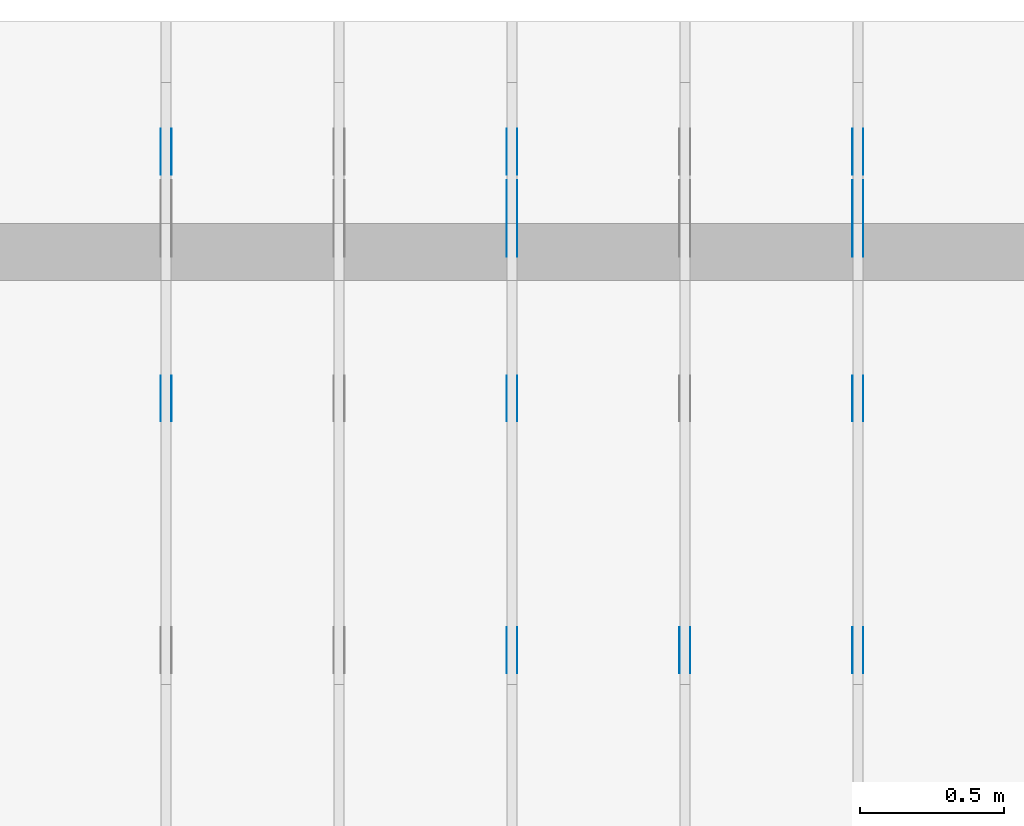
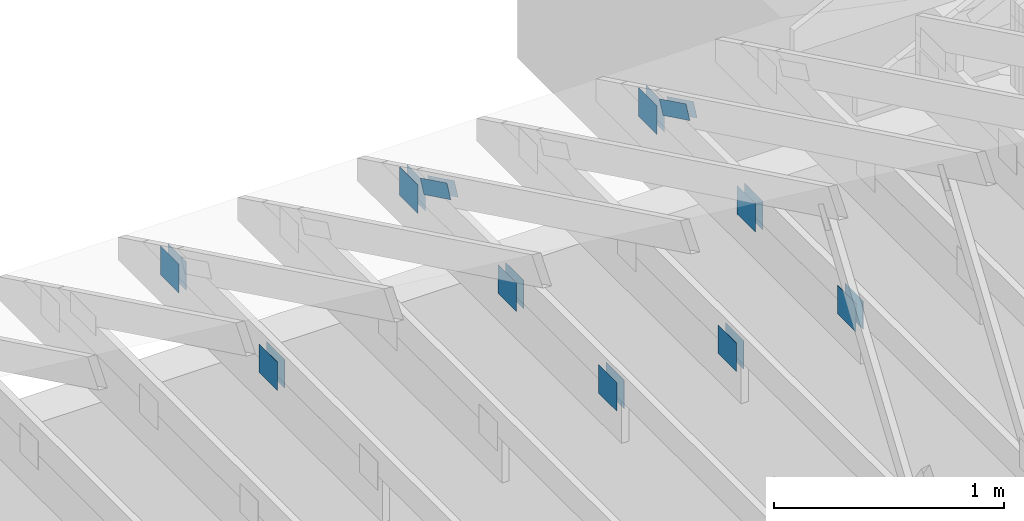
# One storey, part 95 of 159: 22 plates, 4 elements without a shape of their own.
"""IFC2X3 building model written with IfcOpenShell, lengths in millimetres."""

from ifc_helpers import new_model, si_unit, frame, origin, origin_with_axes, origin_2d, place, context, project, spatial, faceted_brep, element, aggregate, save


model = new_model("IFC2X3")

# Units and contexts
model_context = context("Model", 3, precision=1e-05, world=origin())
plan_context = context("Plan", 2, precision=1e-05, world=origin_2d())
ifc_project = project(units=[si_unit("LENGTHUNIT", "METRE", prefix="MILLI"), si_unit("AREAUNIT", "SQUARE_METRE"), si_unit("VOLUMEUNIT", "CUBIC_METRE"), si_unit("SOLIDANGLEUNIT", "STERADIAN"), si_unit("PLANEANGLEUNIT", "RADIAN"), si_unit("MASSUNIT", "GRAM"), si_unit("TIMEUNIT", "SECOND"), si_unit("THERMODYNAMICTEMPERATUREUNIT", "DEGREE_CELSIUS"), si_unit("LUMINOUSINTENSITYUNIT", "LUMEN")], contexts=[model_context, plan_context])

# Site, building, storey
site_placement = place(None, origin_with_axes())
site = spatial("IfcSite", under=ifc_project, at=site_placement, CompositionType="ELEMENT")
building_placement = place(site_placement, origin_with_axes())
building = spatial("IfcBuilding", under=site, at=building_placement, Name="Plan 1", CompositionType="ELEMENT")
storey_placement = place(building_placement, origin_with_axes())
storey = spatial("IfcBuildingStorey", under=building, at=storey_placement, Name="Etasje 1", CompositionType="ELEMENT", Elevation=0.0)

# Assembly, plates
assembly_1_placement = place(storey_placement, frame((9075.022261404752, 9699.99999999999, 1.1021457184401395e-15), z_axis=(-1.0, 1.836909530733566e-16, 6.123031769111886e-17), x_axis=(-1.836909530733566e-16, -1.0, 0.0)))
assembly_1 = element("IfcElementAssembly", 1, at=assembly_1_placement, inside=storey, Name="T2 (93)", AssemblyPlace="FACTORY", PredefinedType="TRUSS")
plate_1_placement = place(assembly_1_placement, frame((584.1466632894789, 280.2959373746887, 0.0), z_axis=(0.0, 0.0, 1.0), x_axis=(0.8987940462991671, 0.43837114678907757, 0.0)))
plate_1 = element("IfcPlate", 2, at=plate_1_placement, Name="GNT100S 76x258", context=model_context, shape_type="Brep", body=[
    faceted_brep([(257.99998123479463, 76.00002691228985, 1.0), (0.0, 76.00002691228985, 1.0), (1.3453948213282274e-05, 1.802431262376558e-05, 1.0), (257.99999468874273, 1.802431262376558e-05, 1.0), (0.0, 76.00002691228985, 0.0), (257.99998123479463, 76.00002691228985, 3.159484163061836e-14), (257.99999468874273, 0.0, 3.1594843278197396e-14), (1.3453948213282274e-05, 0.0, 1.6475790465982693e-21), (258.00000746284013, 8.521039129974861e-06, 1.1615733003639174e-30), (258.00000746284013, 8.521039130036092e-06, 1.0), (7.462840130756376e-06, 8.521039177428358e-06, 1.0), (7.462840130756376e-06, 8.521039177367127e-06, 9.4039548065783e-38), (258.00000746284013, 76.00000852103915, 0.0), (258.00000746284013, 76.00000852103915, 1.0), (258.00000746284013, 8.52103914894542e-06, 1.0), (258.00000746284013, 8.52103914894542e-06, 0.0), (7.462840130756376e-06, 76.0000085210392, 0.0), (7.462840130756376e-06, 76.0000085210392, 1.0), (258.00000746284013, 76.00000852103913, 1.0), (258.00000746284013, 76.00000852103913, -1.5777218104420236e-30), (7.462840130756377e-06, 8.521039177367129e-06, -9.4039548065783e-38), (7.4628401308176075e-06, 8.521039177367129e-06, 1.0), (7.462840140124616e-06, 76.0000085210392, 1.0), (7.4628401400633854e-06, 76.0000085210392, -5.69871103679771e-31)], [[[0, 1, 2, 3]], [[4, 5, 6, 7]], [[8, 9, 10, 11]], [[12, 13, 14, 15]], [[16, 17, 18, 19]], [[20, 21, 22, 23]]]),
])
plate_2_placement = place(assembly_1_placement, frame((584.1466632894789, 280.2959373746887, -37.0), z_axis=(0.0, 0.0, 1.0), x_axis=(0.8987940462991671, 0.43837114678907757, 0.0)))
plate_2 = element("IfcPlate", 3, at=plate_2_placement, Name="GNT100S 76x258", context=model_context, shape_type="Brep", body=[
    faceted_brep([(257.99998123479463, 76.00002691228985, 1.0), (0.0, 76.00002691228985, 1.0), (1.3453948213282274e-05, 1.802431262376558e-05, 1.0), (257.99999468874273, 1.802431262376558e-05, 1.0), (0.0, 76.00002691228985, 0.0), (257.99998123479463, 76.00002691228985, 3.159484163061836e-14), (257.99999468874273, 0.0, 3.1594843278197396e-14), (1.3453948213282274e-05, 0.0, 1.6475790465982693e-21), (258.00000746284013, 8.521039129974861e-06, 1.1615733003639174e-30), (258.00000746284013, 8.521039130036092e-06, 1.0), (7.462840130756376e-06, 8.521039177428358e-06, 1.0), (7.462840130756376e-06, 8.521039177367127e-06, 9.4039548065783e-38), (258.00000746284013, 76.00000852103915, 0.0), (258.00000746284013, 76.00000852103915, 1.0), (258.00000746284013, 8.52103914894542e-06, 1.0), (258.00000746284013, 8.52103914894542e-06, 0.0), (7.462840130756376e-06, 76.0000085210392, 0.0), (7.462840130756376e-06, 76.0000085210392, 1.0), (258.00000746284013, 76.00000852103913, 1.0), (258.00000746284013, 76.00000852103913, -1.5777218104420236e-30), (7.462840130756377e-06, 8.521039177367129e-06, -9.4039548065783e-38), (7.4628401308176075e-06, 8.521039177367129e-06, 1.0), (7.462840140124616e-06, 76.0000085210392, 1.0), (7.4628401400633854e-06, 76.0000085210392, -5.69871103679771e-31)], [[[0, 1, 2, 3]], [[4, 5, 6, 7]], [[8, 9, 10, 11]], [[12, 13, 14, 15]], [[16, 17, 18, 19]], [[20, 21, 22, 23]]]),
])
plate_3_placement = place(assembly_1_placement, frame((2260.0, 299.0, 0.0), z_axis=(0.0, 0.0, 1.0), x_axis=(-1.0, 1.2246063538223773e-16, 0.0)))
plate_3 = element("IfcPlate", 4, at=plate_3_placement, Name="GNT100S 152x159", context=model_context, shape_type="Brep", body=[
    faceted_brep([(159.0, 152.0, 1.0), (0.0, 152.0, 1.0), (0.0, 0.0, 1.0), (159.0, 0.0, 1.0), (0.0, 152.0, 0.0), (159.0, 152.0, 1.9471241025775798e-14), (159.0, 0.0, 1.9471241025775798e-14), (0.0, 0.0, 0.0), (159.0, -2.92068615386637e-14, 1.788345410772899e-30), (159.0, -2.914563122097258e-14, 1.0), (1.1247455413666031e-32, 6.123031769111886e-17, 1.0), (0.0, 0.0, 0.0), (159.0, 152.00000000000003, 0.0), (159.0, 152.00000000000003, 1.0), (159.0, 0.0, 1.0), (159.0, 0.0, 0.0), (0.0, 152.0, 0.0), (0.0, 152.0, 1.0), (159.0, 152.00000000000003, 1.0), (159.0, 152.00000000000003, 0.0), (0.0, 0.0, 0.0), (6.123031769111886e-17, -7.498303609110687e-33, 1.0), (1.8675246895791253e-14, 152.0, 1.0), (1.8614016578100134e-14, 152.0, -1.1397421485848245e-30)], [[[0, 1, 2, 3]], [[4, 5, 6, 7]], [[8, 9, 10, 11]], [[12, 13, 14, 15]], [[16, 17, 18, 19]], [[20, 21, 22, 23]]]),
])
plate_4_placement = place(assembly_1_placement, frame((2260.0, 299.0, -37.0), z_axis=(0.0, 0.0, 1.0), x_axis=(-1.0, 1.2246063538223773e-16, 0.0)))
plate_4 = element("IfcPlate", 5, at=plate_4_placement, Name="GNT100S 152x159", context=model_context, shape_type="Brep", body=[
    faceted_brep([(159.0, 152.0, 1.0), (0.0, 152.0, 1.0), (0.0, 0.0, 1.0), (159.0, 0.0, 1.0), (0.0, 152.0, 0.0), (159.0, 152.0, 1.9471241025775798e-14), (159.0, 0.0, 1.9471241025775798e-14), (0.0, 0.0, 0.0), (159.0, -2.92068615386637e-14, 1.788345410772899e-30), (159.0, -2.914563122097258e-14, 1.0), (1.1247455413666031e-32, 6.123031769111886e-17, 1.0), (0.0, 0.0, 0.0), (159.0, 152.00000000000003, 0.0), (159.0, 152.00000000000003, 1.0), (159.0, 0.0, 1.0), (159.0, 0.0, 0.0), (0.0, 152.0, 0.0), (0.0, 152.0, 1.0), (159.0, 152.00000000000003, 1.0), (159.0, 152.00000000000003, 0.0), (0.0, 0.0, 0.0), (6.123031769111886e-17, -7.498303609110687e-33, 1.0), (1.8675246895791253e-14, 152.0, 1.0), (1.8614016578100134e-14, 152.0, -1.1397421485848245e-30)], [[[0, 1, 2, 3]], [[4, 5, 6, 7]], [[8, 9, 10, 11]], [[12, 13, 14, 15]], [[16, 17, 18, 19]], [[20, 21, 22, 23]]]),
])
plate_5_placement = place(assembly_1_placement, frame((1227.851282296476, 147.0, 0.0), z_axis=(0.0, 0.0, 1.0), x_axis=(1.0, 0.0, 0.0)))
plate_5 = element("IfcPlate", 6, at=plate_5_placement, Name="GNT100S 152x159", context=model_context, shape_type="Brep", body=[
    faceted_brep([(159.00003606289897, 152.0, 1.0), (3.6062898971067625e-05, 152.0, 1.0), (3.6062898971067625e-05, 0.0, 1.0), (159.00003606289897, 0.0, 1.0), (3.6062898971067625e-05, 152.0, 4.4162855217223885e-21), (159.00003606289897, 152.0, 1.947124544206132e-14), (159.00003606289897, 0.0, 1.947124544206132e-14), (3.6062898971067625e-05, 0.0, 4.4162855217223885e-21), (159.0, 8.447997618295233e-14, 1.788345410772899e-30), (159.0, 8.454120650064345e-14, 1.0), (1.1247455413666031e-32, 1.1374806803930715e-13, 1.0), (0.0, 1.1368683772161603e-13, 0.0), (159.0, 152.0000000000001, 0.0), (159.0, 152.0000000000001, 1.0), (159.0, 1.1368683772161603e-13, 1.0), (159.0, 1.1368683772161603e-13, 0.0), (4.861730685829017e-63, 152.0000000000001, 0.0), (-3.7491518045553436e-33, 152.0000000000001, 1.0), (159.0, 152.0000000000001, 1.0), (159.0, 152.0000000000001, 0.0), (1.392216238198645e-29, 1.1368683772161603e-13, -8.524584255963745e-46), (6.123031769113279e-17, 1.1368683772161603e-13, 1.0), (1.8675246895791266e-14, 152.0000000000001, 1.0), (1.8614016578100147e-14, 152.0000000000001, -1.1397421485848253e-30)], [[[0, 1, 2, 3]], [[4, 5, 6, 7]], [[8, 9, 10, 11]], [[12, 13, 14, 15]], [[16, 17, 18, 19]], [[20, 21, 22, 23]]]),
])
plate_6_placement = place(assembly_1_placement, frame((1227.851282296476, 147.0, -37.0), z_axis=(0.0, 0.0, 1.0), x_axis=(1.0, 0.0, 0.0)))
plate_6 = element("IfcPlate", 7, at=plate_6_placement, Name="GNT100S 152x159", context=model_context, shape_type="Brep", body=[
    faceted_brep([(159.00003606289897, 152.0, 1.0), (3.6062898971067625e-05, 152.0, 1.0), (3.6062898971067625e-05, 0.0, 1.0), (159.00003606289897, 0.0, 1.0), (3.6062898971067625e-05, 152.0, 4.4162855217223885e-21), (159.00003606289897, 152.0, 1.947124544206132e-14), (159.00003606289897, 0.0, 1.947124544206132e-14), (3.6062898971067625e-05, 0.0, 4.4162855217223885e-21), (159.0, 8.447997618295233e-14, 1.788345410772899e-30), (159.0, 8.454120650064345e-14, 1.0), (1.1247455413666031e-32, 1.1374806803930715e-13, 1.0), (0.0, 1.1368683772161603e-13, 0.0), (159.0, 152.0000000000001, 0.0), (159.0, 152.0000000000001, 1.0), (159.0, 1.1368683772161603e-13, 1.0), (159.0, 1.1368683772161603e-13, 0.0), (4.861730685829017e-63, 152.0000000000001, 0.0), (-3.7491518045553436e-33, 152.0000000000001, 1.0), (159.0, 152.0000000000001, 1.0), (159.0, 152.0000000000001, 0.0), (1.392216238198645e-29, 1.1368683772161603e-13, -8.524584255963745e-46), (6.123031769113279e-17, 1.1368683772161603e-13, 1.0), (1.8675246895791266e-14, 152.0000000000001, 1.0), (1.8614016578100147e-14, 152.0000000000001, -1.1397421485848253e-30)], [[[0, 1, 2, 3]], [[4, 5, 6, 7]], [[8, 9, 10, 11]], [[12, 13, 14, 15]], [[16, 17, 18, 19]], [[20, 21, 22, 23]]]),
])
plate_7_placement = place(assembly_1_placement, frame((372.12651478826456, 147.0, 0.0), z_axis=(0.0, 0.0, 1.0), x_axis=(1.0, 0.0, 0.0)))
plate_7 = element("IfcPlate", 8, at=plate_7_placement, Name="GNT100S 152x159", context=model_context, shape_type="Brep", body=[
    faceted_brep([(159.0000110906417, 152.0, 1.0), (1.109064169213525e-05, 152.0, 1.0), (1.109064169213525e-05, 0.0, 1.0), (159.0000110906417, 0.0, 1.0), (1.109064169213525e-05, 152.0, 1.3581670284156189e-21), (159.0000110906417, 152.0, 1.9471242383942826e-14), (159.0000110906417, 0.0, 1.9471242383942826e-14), (1.109064169213525e-05, 0.0, 1.3581670284156189e-21), (159.0, 1.9816681390456836e-13, 1.788345410772899e-30), (159.0, 1.9822804422225948e-13, 1.0), (1.1247455413666031e-32, 2.274349057609232e-13, 1.0), (0.0, 2.2737367544323206e-13, 0.0), (159.0, 152.00000000000023, 0.0), (159.0, 152.00000000000023, 1.0), (159.0, 2.2737367544323206e-13, 1.0), (159.0, 2.2737367544323206e-13, 0.0), (0.0, 152.00000000000023, 0.0), (-3.7491518045553436e-33, 152.00000000000023, 1.0), (159.0, 152.00000000000023, 1.0), (159.0, 152.00000000000023, 0.0), (2.78443247639729e-29, 2.2737367544323206e-13, -1.704916851192749e-45), (6.123031769114671e-17, 2.2737367544323206e-13, 1.0), (1.8675246895791282e-14, 152.00000000000023, 1.0), (1.8614016578100163e-14, 152.00000000000023, -1.1397421485848262e-30)], [[[0, 1, 2, 3]], [[4, 5, 6, 7]], [[8, 9, 10, 11]], [[12, 13, 14, 15]], [[16, 17, 18, 19]], [[20, 21, 22, 23]]]),
])
plate_8_placement = place(assembly_1_placement, frame((372.12651478826456, 147.0, -37.0), z_axis=(0.0, 0.0, 1.0), x_axis=(1.0, 0.0, 0.0)))
plate_8 = element("IfcPlate", 9, at=plate_8_placement, Name="GNT100S 152x159", context=model_context, shape_type="Brep", body=[
    faceted_brep([(159.0000110906417, 152.0, 1.0), (1.109064169213525e-05, 152.0, 1.0), (1.109064169213525e-05, 0.0, 1.0), (159.0000110906417, 0.0, 1.0), (1.109064169213525e-05, 152.0, 1.3581670284156189e-21), (159.0000110906417, 152.0, 1.9471242383942826e-14), (159.0000110906417, 0.0, 1.9471242383942826e-14), (1.109064169213525e-05, 0.0, 1.3581670284156189e-21), (159.0, 1.9816681390456836e-13, 1.788345410772899e-30), (159.0, 1.9822804422225948e-13, 1.0), (1.1247455413666031e-32, 2.274349057609232e-13, 1.0), (0.0, 2.2737367544323206e-13, 0.0), (159.0, 152.00000000000023, 0.0), (159.0, 152.00000000000023, 1.0), (159.0, 2.2737367544323206e-13, 1.0), (159.0, 2.2737367544323206e-13, 0.0), (0.0, 152.00000000000023, 0.0), (-3.7491518045553436e-33, 152.00000000000023, 1.0), (159.0, 152.00000000000023, 1.0), (159.0, 152.00000000000023, 0.0), (2.78443247639729e-29, 2.2737367544323206e-13, -1.704916851192749e-45), (6.123031769114671e-17, 2.2737367544323206e-13, 1.0), (1.8675246895791282e-14, 152.00000000000023, 1.0), (1.8614016578100163e-14, 152.00000000000023, -1.1397421485848262e-30)], [[[0, 1, 2, 3]], [[4, 5, 6, 7]], [[8, 9, 10, 11]], [[12, 13, 14, 15]], [[16, 17, 18, 19]], [[20, 21, 22, 23]]]),
])
aggregate(assembly_1, [plate_1, plate_2, plate_3, plate_4, plate_5, plate_6, plate_7, plate_8])

assembly_2_placement = place(storey_placement, frame((8475.022261404752, 9699.99999999999, 1.1021457184401395e-15), z_axis=(-1.0, 1.836909530733566e-16, 6.123031769111886e-17), x_axis=(-1.836909530733566e-16, -1.0, 0.0)))
assembly_2 = element("IfcElementAssembly", 10, at=assembly_2_placement, inside=storey, Name="T2 (92)", AssemblyPlace="FACTORY", PredefinedType="TRUSS")
plate_9_placement = place(assembly_2_placement, frame((2260.0, 299.0, 0.0), z_axis=(0.0, 0.0, 1.0), x_axis=(-1.0, 1.2246063538223773e-16, 0.0)))
plate_9 = element("IfcPlate", 11, at=plate_9_placement, Name="GNT100S 152x159", context=model_context, shape_type="Brep", body=[
    faceted_brep([(159.0, 152.0, 1.0), (0.0, 152.0, 1.0), (0.0, 0.0, 1.0), (159.0, 0.0, 1.0), (0.0, 152.0, 0.0), (159.0, 152.0, 1.9471241025775798e-14), (159.0, 0.0, 1.9471241025775798e-14), (0.0, 0.0, 0.0), (159.0, -2.92068615386637e-14, 1.788345410772899e-30), (159.0, -2.914563122097258e-14, 1.0), (1.1247455413666031e-32, 6.123031769111886e-17, 1.0), (0.0, 0.0, 0.0), (159.0, 152.00000000000003, 0.0), (159.0, 152.00000000000003, 1.0), (159.0, 0.0, 1.0), (159.0, 0.0, 0.0), (0.0, 152.0, 0.0), (0.0, 152.0, 1.0), (159.0, 152.00000000000003, 1.0), (159.0, 152.00000000000003, 0.0), (0.0, 0.0, 0.0), (6.123031769111886e-17, -7.498303609110687e-33, 1.0), (1.8675246895791253e-14, 152.0, 1.0), (1.8614016578100134e-14, 152.0, -1.1397421485848245e-30)], [[[0, 1, 2, 3]], [[4, 5, 6, 7]], [[8, 9, 10, 11]], [[12, 13, 14, 15]], [[16, 17, 18, 19]], [[20, 21, 22, 23]]]),
])
plate_10_placement = place(assembly_2_placement, frame((2260.0, 299.0, -37.0), z_axis=(0.0, 0.0, 1.0), x_axis=(-1.0, 1.2246063538223773e-16, 0.0)))
plate_10 = element("IfcPlate", 12, at=plate_10_placement, Name="GNT100S 152x159", context=model_context, shape_type="Brep", body=[
    faceted_brep([(159.0, 152.0, 1.0), (0.0, 152.0, 1.0), (0.0, 0.0, 1.0), (159.0, 0.0, 1.0), (0.0, 152.0, 0.0), (159.0, 152.0, 1.9471241025775798e-14), (159.0, 0.0, 1.9471241025775798e-14), (0.0, 0.0, 0.0), (159.0, -2.92068615386637e-14, 1.788345410772899e-30), (159.0, -2.914563122097258e-14, 1.0), (1.1247455413666031e-32, 6.123031769111886e-17, 1.0), (0.0, 0.0, 0.0), (159.0, 152.00000000000003, 0.0), (159.0, 152.00000000000003, 1.0), (159.0, 0.0, 1.0), (159.0, 0.0, 0.0), (0.0, 152.0, 0.0), (0.0, 152.0, 1.0), (159.0, 152.00000000000003, 1.0), (159.0, 152.00000000000003, 0.0), (0.0, 0.0, 0.0), (6.123031769111886e-17, -7.498303609110687e-33, 1.0), (1.8675246895791253e-14, 152.0, 1.0), (1.8614016578100134e-14, 152.0, -1.1397421485848245e-30)], [[[0, 1, 2, 3]], [[4, 5, 6, 7]], [[8, 9, 10, 11]], [[12, 13, 14, 15]], [[16, 17, 18, 19]], [[20, 21, 22, 23]]]),
])
aggregate(assembly_2, [plate_9, plate_10])

assembly_3_placement = place(storey_placement, frame((7875.0222614047525, 9699.99999999999, 1.1021457184401395e-15), z_axis=(-1.0, 1.836909530733566e-16, 6.123031769111886e-17), x_axis=(-1.836909530733566e-16, -1.0, 0.0)))
assembly_3 = element("IfcElementAssembly", 13, at=assembly_3_placement, inside=storey, Name="T2 (91)", AssemblyPlace="FACTORY", PredefinedType="TRUSS")
plate_11_placement = place(assembly_3_placement, frame((584.1466632894789, 280.2959373746887, 0.0), z_axis=(0.0, 0.0, 1.0), x_axis=(0.8987940462991671, 0.43837114678907757, 0.0)))
plate_11 = element("IfcPlate", 14, at=plate_11_placement, Name="GNT100S 76x258", context=model_context, shape_type="Brep", body=[
    faceted_brep([(257.99998123479463, 76.00002691228985, 1.0), (0.0, 76.00002691228985, 1.0), (1.3453948213282274e-05, 1.802431262376558e-05, 1.0), (257.99999468874273, 1.802431262376558e-05, 1.0), (0.0, 76.00002691228985, 0.0), (257.99998123479463, 76.00002691228985, 3.159484163061836e-14), (257.99999468874273, 0.0, 3.1594843278197396e-14), (1.3453948213282274e-05, 0.0, 1.6475790465982693e-21), (258.00000746284013, 8.521039129974861e-06, 1.1615733003639174e-30), (258.00000746284013, 8.521039130036092e-06, 1.0), (7.462840130756376e-06, 8.521039177428358e-06, 1.0), (7.462840130756376e-06, 8.521039177367127e-06, 9.4039548065783e-38), (258.00000746284013, 76.00000852103915, 0.0), (258.00000746284013, 76.00000852103915, 1.0), (258.00000746284013, 8.52103914894542e-06, 1.0), (258.00000746284013, 8.52103914894542e-06, 0.0), (7.462840130756376e-06, 76.0000085210392, 0.0), (7.462840130756376e-06, 76.0000085210392, 1.0), (258.00000746284013, 76.00000852103913, 1.0), (258.00000746284013, 76.00000852103913, -1.5777218104420236e-30), (7.462840130756377e-06, 8.521039177367129e-06, -9.4039548065783e-38), (7.4628401308176075e-06, 8.521039177367129e-06, 1.0), (7.462840140124616e-06, 76.0000085210392, 1.0), (7.4628401400633854e-06, 76.0000085210392, -5.69871103679771e-31)], [[[0, 1, 2, 3]], [[4, 5, 6, 7]], [[8, 9, 10, 11]], [[12, 13, 14, 15]], [[16, 17, 18, 19]], [[20, 21, 22, 23]]]),
])
plate_12_placement = place(assembly_3_placement, frame((584.1466632894789, 280.2959373746887, -37.0), z_axis=(0.0, 0.0, 1.0), x_axis=(0.8987940462991671, 0.43837114678907757, 0.0)))
plate_12 = element("IfcPlate", 15, at=plate_12_placement, Name="GNT100S 76x258", context=model_context, shape_type="Brep", body=[
    faceted_brep([(257.99998123479463, 76.00002691228985, 1.0), (0.0, 76.00002691228985, 1.0), (1.3453948213282274e-05, 1.802431262376558e-05, 1.0), (257.99999468874273, 1.802431262376558e-05, 1.0), (0.0, 76.00002691228985, 0.0), (257.99998123479463, 76.00002691228985, 3.159484163061836e-14), (257.99999468874273, 0.0, 3.1594843278197396e-14), (1.3453948213282274e-05, 0.0, 1.6475790465982693e-21), (258.00000746284013, 8.521039129974861e-06, 1.1615733003639174e-30), (258.00000746284013, 8.521039130036092e-06, 1.0), (7.462840130756376e-06, 8.521039177428358e-06, 1.0), (7.462840130756376e-06, 8.521039177367127e-06, 9.4039548065783e-38), (258.00000746284013, 76.00000852103915, 0.0), (258.00000746284013, 76.00000852103915, 1.0), (258.00000746284013, 8.52103914894542e-06, 1.0), (258.00000746284013, 8.52103914894542e-06, 0.0), (7.462840130756376e-06, 76.0000085210392, 0.0), (7.462840130756376e-06, 76.0000085210392, 1.0), (258.00000746284013, 76.00000852103913, 1.0), (258.00000746284013, 76.00000852103913, -1.5777218104420236e-30), (7.462840130756377e-06, 8.521039177367129e-06, -9.4039548065783e-38), (7.4628401308176075e-06, 8.521039177367129e-06, 1.0), (7.462840140124616e-06, 76.0000085210392, 1.0), (7.4628401400633854e-06, 76.0000085210392, -5.69871103679771e-31)], [[[0, 1, 2, 3]], [[4, 5, 6, 7]], [[8, 9, 10, 11]], [[12, 13, 14, 15]], [[16, 17, 18, 19]], [[20, 21, 22, 23]]]),
])
plate_13_placement = place(assembly_3_placement, frame((2260.0, 299.0, 0.0), z_axis=(0.0, 0.0, 1.0), x_axis=(-1.0, 1.2246063538223773e-16, 0.0)))
plate_13 = element("IfcPlate", 16, at=plate_13_placement, Name="GNT100S 152x159", context=model_context, shape_type="Brep", body=[
    faceted_brep([(159.0, 152.0, 1.0), (0.0, 152.0, 1.0), (0.0, 0.0, 1.0), (159.0, 0.0, 1.0), (0.0, 152.0, 0.0), (159.0, 152.0, 1.9471241025775798e-14), (159.0, 0.0, 1.9471241025775798e-14), (0.0, 0.0, 0.0), (159.0, -2.92068615386637e-14, 1.788345410772899e-30), (159.0, -2.914563122097258e-14, 1.0), (1.1247455413666031e-32, 6.123031769111886e-17, 1.0), (0.0, 0.0, 0.0), (159.0, 152.00000000000003, 0.0), (159.0, 152.00000000000003, 1.0), (159.0, 0.0, 1.0), (159.0, 0.0, 0.0), (0.0, 152.0, 0.0), (0.0, 152.0, 1.0), (159.0, 152.00000000000003, 1.0), (159.0, 152.00000000000003, 0.0), (0.0, 0.0, 0.0), (6.123031769111886e-17, -7.498303609110687e-33, 1.0), (1.8675246895791253e-14, 152.0, 1.0), (1.8614016578100134e-14, 152.0, -1.1397421485848245e-30)], [[[0, 1, 2, 3]], [[4, 5, 6, 7]], [[8, 9, 10, 11]], [[12, 13, 14, 15]], [[16, 17, 18, 19]], [[20, 21, 22, 23]]]),
])
plate_14_placement = place(assembly_3_placement, frame((2260.0, 299.0, -37.0), z_axis=(0.0, 0.0, 1.0), x_axis=(-1.0, 1.2246063538223773e-16, 0.0)))
plate_14 = element("IfcPlate", 17, at=plate_14_placement, Name="GNT100S 152x159", context=model_context, shape_type="Brep", body=[
    faceted_brep([(159.0, 152.0, 1.0), (0.0, 152.0, 1.0), (0.0, 0.0, 1.0), (159.0, 0.0, 1.0), (0.0, 152.0, 0.0), (159.0, 152.0, 1.9471241025775798e-14), (159.0, 0.0, 1.9471241025775798e-14), (0.0, 0.0, 0.0), (159.0, -2.92068615386637e-14, 1.788345410772899e-30), (159.0, -2.914563122097258e-14, 1.0), (1.1247455413666031e-32, 6.123031769111886e-17, 1.0), (0.0, 0.0, 0.0), (159.0, 152.00000000000003, 0.0), (159.0, 152.00000000000003, 1.0), (159.0, 0.0, 1.0), (159.0, 0.0, 0.0), (0.0, 152.0, 0.0), (0.0, 152.0, 1.0), (159.0, 152.00000000000003, 1.0), (159.0, 152.00000000000003, 0.0), (0.0, 0.0, 0.0), (6.123031769111886e-17, -7.498303609110687e-33, 1.0), (1.8675246895791253e-14, 152.0, 1.0), (1.8614016578100134e-14, 152.0, -1.1397421485848245e-30)], [[[0, 1, 2, 3]], [[4, 5, 6, 7]], [[8, 9, 10, 11]], [[12, 13, 14, 15]], [[16, 17, 18, 19]], [[20, 21, 22, 23]]]),
])
plate_15_placement = place(assembly_3_placement, frame((1227.851282296476, 147.0, 0.0), z_axis=(0.0, 0.0, 1.0), x_axis=(1.0, 0.0, 0.0)))
plate_15 = element("IfcPlate", 18, at=plate_15_placement, Name="GNT100S 152x159", context=model_context, shape_type="Brep", body=[
    faceted_brep([(159.00003606289897, 152.0, 1.0), (3.6062898971067625e-05, 152.0, 1.0), (3.6062898971067625e-05, 0.0, 1.0), (159.00003606289897, 0.0, 1.0), (3.6062898971067625e-05, 152.0, 4.4162855217223885e-21), (159.00003606289897, 152.0, 1.947124544206132e-14), (159.00003606289897, 0.0, 1.947124544206132e-14), (3.6062898971067625e-05, 0.0, 4.4162855217223885e-21), (159.0, 8.447997618295233e-14, 1.788345410772899e-30), (159.0, 8.454120650064345e-14, 1.0), (1.1247455413666031e-32, 1.1374806803930715e-13, 1.0), (0.0, 1.1368683772161603e-13, 0.0), (159.0, 152.0000000000001, 0.0), (159.0, 152.0000000000001, 1.0), (159.0, 1.1368683772161603e-13, 1.0), (159.0, 1.1368683772161603e-13, 0.0), (4.861730685829017e-63, 152.0000000000001, 0.0), (-3.7491518045553436e-33, 152.0000000000001, 1.0), (159.0, 152.0000000000001, 1.0), (159.0, 152.0000000000001, 0.0), (1.392216238198645e-29, 1.1368683772161603e-13, -8.524584255963745e-46), (6.123031769113279e-17, 1.1368683772161603e-13, 1.0), (1.8675246895791266e-14, 152.0000000000001, 1.0), (1.8614016578100147e-14, 152.0000000000001, -1.1397421485848253e-30)], [[[0, 1, 2, 3]], [[4, 5, 6, 7]], [[8, 9, 10, 11]], [[12, 13, 14, 15]], [[16, 17, 18, 19]], [[20, 21, 22, 23]]]),
])
plate_16_placement = place(assembly_3_placement, frame((1227.851282296476, 147.0, -37.0), z_axis=(0.0, 0.0, 1.0), x_axis=(1.0, 0.0, 0.0)))
plate_16 = element("IfcPlate", 19, at=plate_16_placement, Name="GNT100S 152x159", context=model_context, shape_type="Brep", body=[
    faceted_brep([(159.00003606289897, 152.0, 1.0), (3.6062898971067625e-05, 152.0, 1.0), (3.6062898971067625e-05, 0.0, 1.0), (159.00003606289897, 0.0, 1.0), (3.6062898971067625e-05, 152.0, 4.4162855217223885e-21), (159.00003606289897, 152.0, 1.947124544206132e-14), (159.00003606289897, 0.0, 1.947124544206132e-14), (3.6062898971067625e-05, 0.0, 4.4162855217223885e-21), (159.0, 8.447997618295233e-14, 1.788345410772899e-30), (159.0, 8.454120650064345e-14, 1.0), (1.1247455413666031e-32, 1.1374806803930715e-13, 1.0), (0.0, 1.1368683772161603e-13, 0.0), (159.0, 152.0000000000001, 0.0), (159.0, 152.0000000000001, 1.0), (159.0, 1.1368683772161603e-13, 1.0), (159.0, 1.1368683772161603e-13, 0.0), (4.861730685829017e-63, 152.0000000000001, 0.0), (-3.7491518045553436e-33, 152.0000000000001, 1.0), (159.0, 152.0000000000001, 1.0), (159.0, 152.0000000000001, 0.0), (1.392216238198645e-29, 1.1368683772161603e-13, -8.524584255963745e-46), (6.123031769113279e-17, 1.1368683772161603e-13, 1.0), (1.8675246895791266e-14, 152.0000000000001, 1.0), (1.8614016578100147e-14, 152.0000000000001, -1.1397421485848253e-30)], [[[0, 1, 2, 3]], [[4, 5, 6, 7]], [[8, 9, 10, 11]], [[12, 13, 14, 15]], [[16, 17, 18, 19]], [[20, 21, 22, 23]]]),
])
plate_17_placement = place(assembly_3_placement, frame((372.12651478826456, 147.0, 0.0), z_axis=(0.0, 0.0, 1.0), x_axis=(1.0, 0.0, 0.0)))
plate_17 = element("IfcPlate", 20, at=plate_17_placement, Name="GNT100S 152x159", context=model_context, shape_type="Brep", body=[
    faceted_brep([(159.0000110906417, 152.0, 1.0), (1.109064169213525e-05, 152.0, 1.0), (1.109064169213525e-05, 0.0, 1.0), (159.0000110906417, 0.0, 1.0), (1.109064169213525e-05, 152.0, 1.3581670284156189e-21), (159.0000110906417, 152.0, 1.9471242383942826e-14), (159.0000110906417, 0.0, 1.9471242383942826e-14), (1.109064169213525e-05, 0.0, 1.3581670284156189e-21), (159.0, 1.9816681390456836e-13, 1.788345410772899e-30), (159.0, 1.9822804422225948e-13, 1.0), (1.1247455413666031e-32, 2.274349057609232e-13, 1.0), (0.0, 2.2737367544323206e-13, 0.0), (159.0, 152.00000000000023, 0.0), (159.0, 152.00000000000023, 1.0), (159.0, 2.2737367544323206e-13, 1.0), (159.0, 2.2737367544323206e-13, 0.0), (0.0, 152.00000000000023, 0.0), (-3.7491518045553436e-33, 152.00000000000023, 1.0), (159.0, 152.00000000000023, 1.0), (159.0, 152.00000000000023, 0.0), (2.78443247639729e-29, 2.2737367544323206e-13, -1.704916851192749e-45), (6.123031769114671e-17, 2.2737367544323206e-13, 1.0), (1.8675246895791282e-14, 152.00000000000023, 1.0), (1.8614016578100163e-14, 152.00000000000023, -1.1397421485848262e-30)], [[[0, 1, 2, 3]], [[4, 5, 6, 7]], [[8, 9, 10, 11]], [[12, 13, 14, 15]], [[16, 17, 18, 19]], [[20, 21, 22, 23]]]),
])
plate_18_placement = place(assembly_3_placement, frame((372.12651478826456, 147.0, -37.0), z_axis=(0.0, 0.0, 1.0), x_axis=(1.0, 0.0, 0.0)))
plate_18 = element("IfcPlate", 21, at=plate_18_placement, Name="GNT100S 152x159", context=model_context, shape_type="Brep", body=[
    faceted_brep([(159.0000110906417, 152.0, 1.0), (1.109064169213525e-05, 152.0, 1.0), (1.109064169213525e-05, 0.0, 1.0), (159.0000110906417, 0.0, 1.0), (1.109064169213525e-05, 152.0, 1.3581670284156189e-21), (159.0000110906417, 152.0, 1.9471242383942826e-14), (159.0000110906417, 0.0, 1.9471242383942826e-14), (1.109064169213525e-05, 0.0, 1.3581670284156189e-21), (159.0, 1.9816681390456836e-13, 1.788345410772899e-30), (159.0, 1.9822804422225948e-13, 1.0), (1.1247455413666031e-32, 2.274349057609232e-13, 1.0), (0.0, 2.2737367544323206e-13, 0.0), (159.0, 152.00000000000023, 0.0), (159.0, 152.00000000000023, 1.0), (159.0, 2.2737367544323206e-13, 1.0), (159.0, 2.2737367544323206e-13, 0.0), (0.0, 152.00000000000023, 0.0), (-3.7491518045553436e-33, 152.00000000000023, 1.0), (159.0, 152.00000000000023, 1.0), (159.0, 152.00000000000023, 0.0), (2.78443247639729e-29, 2.2737367544323206e-13, -1.704916851192749e-45), (6.123031769114671e-17, 2.2737367544323206e-13, 1.0), (1.8675246895791282e-14, 152.00000000000023, 1.0), (1.8614016578100163e-14, 152.00000000000023, -1.1397421485848262e-30)], [[[0, 1, 2, 3]], [[4, 5, 6, 7]], [[8, 9, 10, 11]], [[12, 13, 14, 15]], [[16, 17, 18, 19]], [[20, 21, 22, 23]]]),
])
aggregate(assembly_3, [plate_11, plate_12, plate_13, plate_14, plate_15, plate_16, plate_17, plate_18])

assembly_4_placement = place(storey_placement, frame((6675.0222614047525, 9699.99999999999, 1.1021457184401395e-15), z_axis=(-1.0, 1.836909530733566e-16, 6.123031769111886e-17), x_axis=(-1.836909530733566e-16, -1.0, 0.0)))
assembly_4 = element("IfcElementAssembly", 22, at=assembly_4_placement, inside=storey, Name="T2 (89)", AssemblyPlace="FACTORY", PredefinedType="TRUSS")
plate_19_placement = place(assembly_4_placement, frame((1227.851282296476, 147.0, 0.0), z_axis=(0.0, 0.0, 1.0), x_axis=(1.0, 0.0, 0.0)))
plate_19 = element("IfcPlate", 23, at=plate_19_placement, Name="GNT100S 152x159", context=model_context, shape_type="Brep", body=[
    faceted_brep([(159.00003606289897, 152.0, 1.0), (3.6062898971067625e-05, 152.0, 1.0), (3.6062898971067625e-05, 0.0, 1.0), (159.00003606289897, 0.0, 1.0), (3.6062898971067625e-05, 152.0, 4.4162855217223885e-21), (159.00003606289897, 152.0, 1.947124544206132e-14), (159.00003606289897, 0.0, 1.947124544206132e-14), (3.6062898971067625e-05, 0.0, 4.4162855217223885e-21), (159.0, 8.447997618295233e-14, 1.788345410772899e-30), (159.0, 8.454120650064345e-14, 1.0), (1.1247455413666031e-32, 1.1374806803930715e-13, 1.0), (0.0, 1.1368683772161603e-13, 0.0), (159.0, 152.0000000000001, 0.0), (159.0, 152.0000000000001, 1.0), (159.0, 1.1368683772161603e-13, 1.0), (159.0, 1.1368683772161603e-13, 0.0), (4.861730685829017e-63, 152.0000000000001, 0.0), (-3.7491518045553436e-33, 152.0000000000001, 1.0), (159.0, 152.0000000000001, 1.0), (159.0, 152.0000000000001, 0.0), (1.392216238198645e-29, 1.1368683772161603e-13, -8.524584255963745e-46), (6.123031769113279e-17, 1.1368683772161603e-13, 1.0), (1.8675246895791266e-14, 152.0000000000001, 1.0), (1.8614016578100147e-14, 152.0000000000001, -1.1397421485848253e-30)], [[[0, 1, 2, 3]], [[4, 5, 6, 7]], [[8, 9, 10, 11]], [[12, 13, 14, 15]], [[16, 17, 18, 19]], [[20, 21, 22, 23]]]),
])
plate_20_placement = place(assembly_4_placement, frame((1227.851282296476, 147.0, -37.0), z_axis=(0.0, 0.0, 1.0), x_axis=(1.0, 0.0, 0.0)))
plate_20 = element("IfcPlate", 24, at=plate_20_placement, Name="GNT100S 152x159", context=model_context, shape_type="Brep", body=[
    faceted_brep([(159.00003606289897, 152.0, 1.0), (3.6062898971067625e-05, 152.0, 1.0), (3.6062898971067625e-05, 0.0, 1.0), (159.00003606289897, 0.0, 1.0), (3.6062898971067625e-05, 152.0, 4.4162855217223885e-21), (159.00003606289897, 152.0, 1.947124544206132e-14), (159.00003606289897, 0.0, 1.947124544206132e-14), (3.6062898971067625e-05, 0.0, 4.4162855217223885e-21), (159.0, 8.447997618295233e-14, 1.788345410772899e-30), (159.0, 8.454120650064345e-14, 1.0), (1.1247455413666031e-32, 1.1374806803930715e-13, 1.0), (0.0, 1.1368683772161603e-13, 0.0), (159.0, 152.0000000000001, 0.0), (159.0, 152.0000000000001, 1.0), (159.0, 1.1368683772161603e-13, 1.0), (159.0, 1.1368683772161603e-13, 0.0), (4.861730685829017e-63, 152.0000000000001, 0.0), (-3.7491518045553436e-33, 152.0000000000001, 1.0), (159.0, 152.0000000000001, 1.0), (159.0, 152.0000000000001, 0.0), (1.392216238198645e-29, 1.1368683772161603e-13, -8.524584255963745e-46), (6.123031769113279e-17, 1.1368683772161603e-13, 1.0), (1.8675246895791266e-14, 152.0000000000001, 1.0), (1.8614016578100147e-14, 152.0000000000001, -1.1397421485848253e-30)], [[[0, 1, 2, 3]], [[4, 5, 6, 7]], [[8, 9, 10, 11]], [[12, 13, 14, 15]], [[16, 17, 18, 19]], [[20, 21, 22, 23]]]),
])
plate_21_placement = place(assembly_4_placement, frame((372.12651478826456, 147.0, 0.0), z_axis=(0.0, 0.0, 1.0), x_axis=(1.0, 0.0, 0.0)))
plate_21 = element("IfcPlate", 25, at=plate_21_placement, Name="GNT100S 152x159", context=model_context, shape_type="Brep", body=[
    faceted_brep([(159.0000110906417, 152.0, 1.0), (1.109064169213525e-05, 152.0, 1.0), (1.109064169213525e-05, 0.0, 1.0), (159.0000110906417, 0.0, 1.0), (1.109064169213525e-05, 152.0, 1.3581670284156189e-21), (159.0000110906417, 152.0, 1.9471242383942826e-14), (159.0000110906417, 0.0, 1.9471242383942826e-14), (1.109064169213525e-05, 0.0, 1.3581670284156189e-21), (159.0, 1.9816681390456836e-13, 1.788345410772899e-30), (159.0, 1.9822804422225948e-13, 1.0), (1.1247455413666031e-32, 2.274349057609232e-13, 1.0), (0.0, 2.2737367544323206e-13, 0.0), (159.0, 152.00000000000023, 0.0), (159.0, 152.00000000000023, 1.0), (159.0, 2.2737367544323206e-13, 1.0), (159.0, 2.2737367544323206e-13, 0.0), (0.0, 152.00000000000023, 0.0), (-3.7491518045553436e-33, 152.00000000000023, 1.0), (159.0, 152.00000000000023, 1.0), (159.0, 152.00000000000023, 0.0), (2.78443247639729e-29, 2.2737367544323206e-13, -1.704916851192749e-45), (6.123031769114671e-17, 2.2737367544323206e-13, 1.0), (1.8675246895791282e-14, 152.00000000000023, 1.0), (1.8614016578100163e-14, 152.00000000000023, -1.1397421485848262e-30)], [[[0, 1, 2, 3]], [[4, 5, 6, 7]], [[8, 9, 10, 11]], [[12, 13, 14, 15]], [[16, 17, 18, 19]], [[20, 21, 22, 23]]]),
])
plate_22_placement = place(assembly_4_placement, frame((372.12651478826456, 147.0, -37.0), z_axis=(0.0, 0.0, 1.0), x_axis=(1.0, 0.0, 0.0)))
plate_22 = element("IfcPlate", 26, at=plate_22_placement, Name="GNT100S 152x159", context=model_context, shape_type="Brep", body=[
    faceted_brep([(159.0000110906417, 152.0, 1.0), (1.109064169213525e-05, 152.0, 1.0), (1.109064169213525e-05, 0.0, 1.0), (159.0000110906417, 0.0, 1.0), (1.109064169213525e-05, 152.0, 1.3581670284156189e-21), (159.0000110906417, 152.0, 1.9471242383942826e-14), (159.0000110906417, 0.0, 1.9471242383942826e-14), (1.109064169213525e-05, 0.0, 1.3581670284156189e-21), (159.0, 1.9816681390456836e-13, 1.788345410772899e-30), (159.0, 1.9822804422225948e-13, 1.0), (1.1247455413666031e-32, 2.274349057609232e-13, 1.0), (0.0, 2.2737367544323206e-13, 0.0), (159.0, 152.00000000000023, 0.0), (159.0, 152.00000000000023, 1.0), (159.0, 2.2737367544323206e-13, 1.0), (159.0, 2.2737367544323206e-13, 0.0), (0.0, 152.00000000000023, 0.0), (-3.7491518045553436e-33, 152.00000000000023, 1.0), (159.0, 152.00000000000023, 1.0), (159.0, 152.00000000000023, 0.0), (2.78443247639729e-29, 2.2737367544323206e-13, -1.704916851192749e-45), (6.123031769114671e-17, 2.2737367544323206e-13, 1.0), (1.8675246895791282e-14, 152.00000000000023, 1.0), (1.8614016578100163e-14, 152.00000000000023, -1.1397421485848262e-30)], [[[0, 1, 2, 3]], [[4, 5, 6, 7]], [[8, 9, 10, 11]], [[12, 13, 14, 15]], [[16, 17, 18, 19]], [[20, 21, 22, 23]]]),
])
aggregate(assembly_4, [plate_19, plate_20, plate_21, plate_22])

save(model, "model.ifc")
